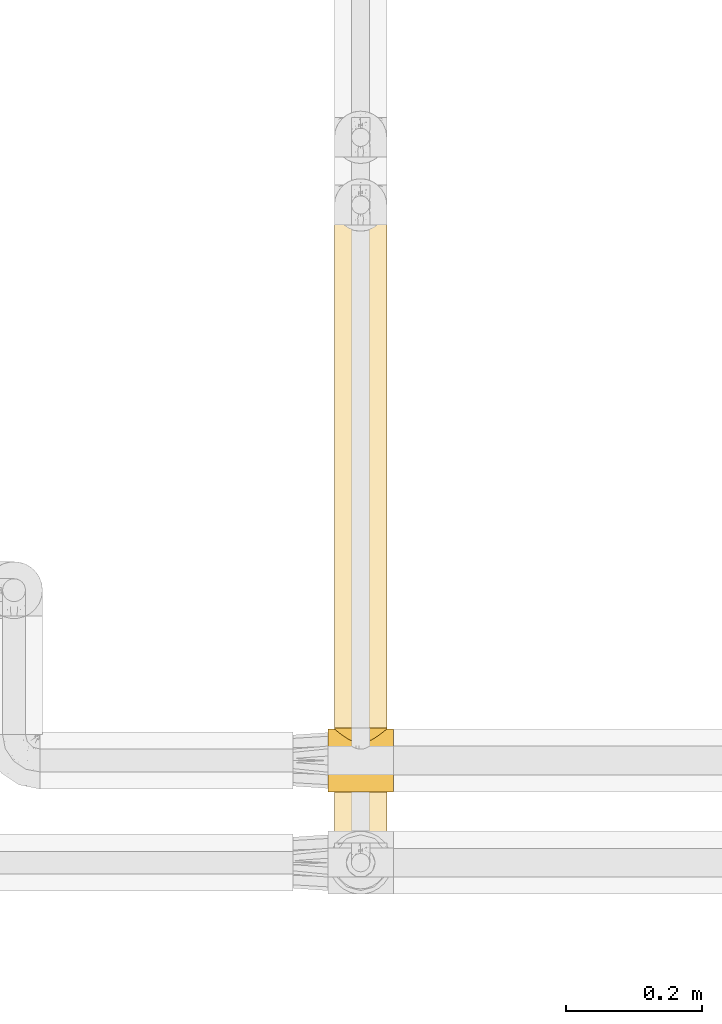
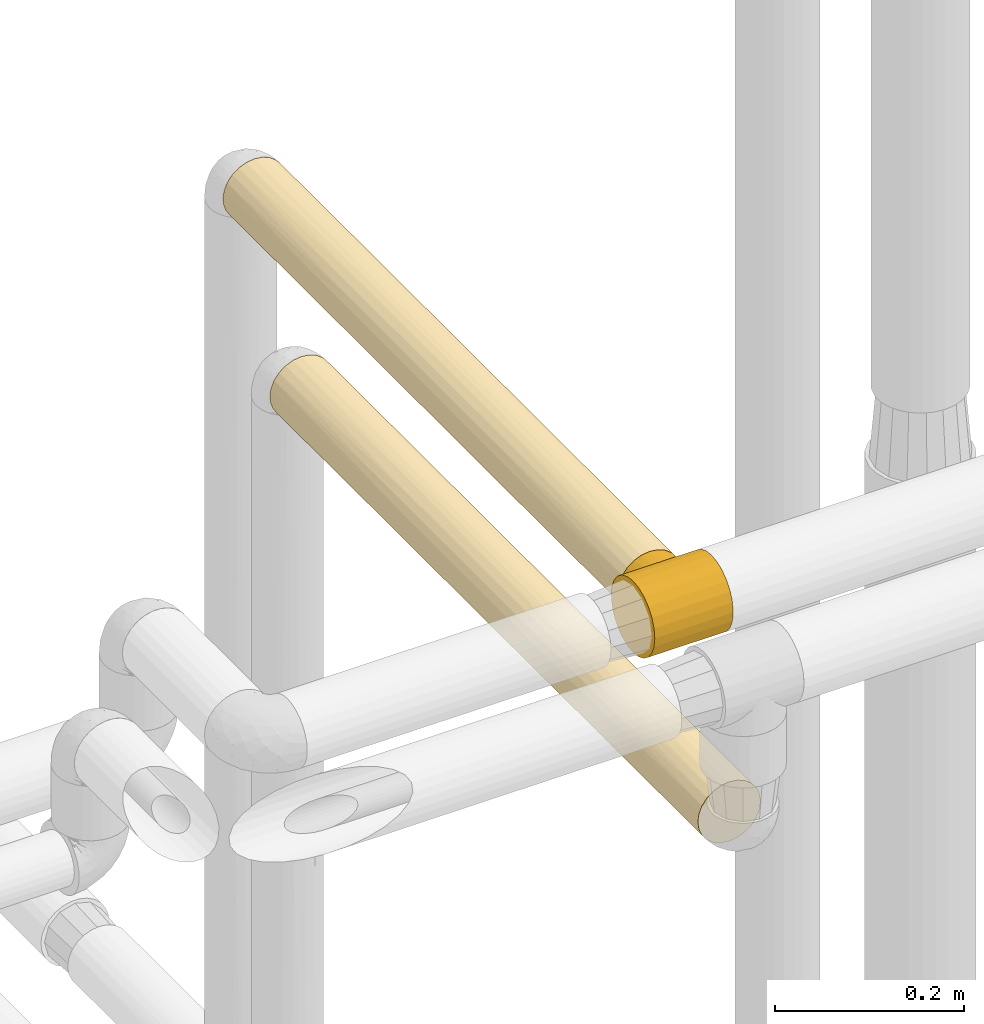
# One storey, part 98 of 827: 3 coverings.
"""IFC2X3 building model written with IfcOpenShell, lengths in millimetres."""

from ifc_helpers import new_model, entity, si_unit, converted_unit, derived_unit, direction, frame, origin, place, context, subcontext, project, spatial, faceted_brep, element, save


model = new_model("IFC2X3")

# Units and contexts
model_context = context("Model", 3, precision=0.01, world=origin(), true_north=direction((6.12303176911189e-17, 1.0)))
body_context = subcontext(model_context, "Body", "Model", "MODEL_VIEW")
ifc_project = project(units=[si_unit("LENGTHUNIT", "METRE", prefix="MILLI"), si_unit("AREAUNIT", "SQUARE_METRE"), si_unit("VOLUMEUNIT", "CUBIC_METRE"), converted_unit("PLANEANGLEUNIT", "DEGREE", entity("IfcRatioMeasure", 0.0174532925199433), si_unit("PLANEANGLEUNIT", "RADIAN"), dimensions=[0, 0, 0, 0, 0, 0, 0]), si_unit("MASSUNIT", "GRAM", prefix="KILO"), derived_unit("MASSDENSITYUNIT", [(si_unit("MASSUNIT", "GRAM", prefix="KILO"), 1), (si_unit("LENGTHUNIT", "METRE"), -3)]), derived_unit("MOMENTOFINERTIAUNIT", [(si_unit("LENGTHUNIT", "METRE"), 4)]), si_unit("TIMEUNIT", "SECOND"), si_unit("FREQUENCYUNIT", "HERTZ"), si_unit("THERMODYNAMICTEMPERATUREUNIT", "DEGREE_CELSIUS"), derived_unit("THERMALTRANSMITTANCEUNIT", [(si_unit("MASSUNIT", "GRAM", prefix="KILO"), 1), (si_unit("THERMODYNAMICTEMPERATUREUNIT", "KELVIN"), -1), (si_unit("TIMEUNIT", "SECOND"), -3)]), derived_unit("VOLUMETRICFLOWRATEUNIT", [(si_unit("LENGTHUNIT", "METRE"), 3), (si_unit("TIMEUNIT", "SECOND"), -1)]), derived_unit("MASSFLOWRATEUNIT", [(si_unit("MASSUNIT", "GRAM", prefix="KILO"), 1), (si_unit("TIMEUNIT", "SECOND"), -1)]), derived_unit("ROTATIONALFREQUENCYUNIT", [(si_unit("TIMEUNIT", "SECOND"), -1)]), si_unit("ELECTRICCURRENTUNIT", "AMPERE"), si_unit("ELECTRICVOLTAGEUNIT", "VOLT"), si_unit("POWERUNIT", "WATT"), si_unit("FORCEUNIT", "NEWTON", prefix="KILO"), si_unit("ILLUMINANCEUNIT", "LUX"), si_unit("LUMINOUSFLUXUNIT", "LUMEN"), si_unit("LUMINOUSINTENSITYUNIT", "CANDELA"), derived_unit("USERDEFINED", [(si_unit("MASSUNIT", "GRAM", prefix="KILO"), -1), (si_unit("LENGTHUNIT", "METRE"), -2), (si_unit("TIMEUNIT", "SECOND"), 3), (si_unit("LUMINOUSFLUXUNIT", "LUMEN"), 1)]), derived_unit("LINEARVELOCITYUNIT", [(si_unit("LENGTHUNIT", "METRE"), 1), (si_unit("TIMEUNIT", "SECOND"), -1)]), si_unit("PRESSUREUNIT", "PASCAL"), derived_unit("USERDEFINED", [(si_unit("LENGTHUNIT", "METRE"), -2), (si_unit("MASSUNIT", "GRAM", prefix="KILO"), 1), (si_unit("TIMEUNIT", "SECOND"), -2)]), derived_unit("LINEARFORCEUNIT", [(si_unit("MASSUNIT", "GRAM", prefix="KILO"), 1), (si_unit("LENGTHUNIT", "METRE"), 1), (si_unit("TIMEUNIT", "SECOND"), -2), (si_unit("LENGTHUNIT", "METRE"), -1)]), derived_unit("PLANARFORCEUNIT", [(si_unit("MASSUNIT", "GRAM", prefix="KILO"), 1), (si_unit("LENGTHUNIT", "METRE"), 1), (si_unit("TIMEUNIT", "SECOND"), -2), (si_unit("LENGTHUNIT", "METRE"), -2)])], contexts=[model_context])

# Site, building, storey
site_placement = place(None, origin())
site = spatial("IfcSite", under=ifc_project, at=site_placement, CompositionType="ELEMENT")
building_placement = place(site_placement, origin())
building = spatial("IfcBuilding", under=site, at=building_placement, CompositionType="ELEMENT")
storey_placement = place(building_placement, frame((0.0, 0.0, 28200.0)))
storey = spatial("IfcBuildingStorey", under=building, at=storey_placement, Name="08", CompositionType="ELEMENT", Elevation=28200.0)

# Coverings
covering_1_placement = place(storey_placement, frame((19736.27, 9540.79, 2957.23)))
element("IfcCovering", 1, at=covering_1_placement, inside=storey, Name=":ADSK_", ObjectType=":ADSK_", PredefinedType="INSULATION", context=body_context, shape_type="Brep", body=[
    faceted_brep([(30.06, 0.01, 2.9), (40.0, 0.01, 1.6), (49.93, 0.01, 2.9), (59.2, 0.01, 6.74), (67.15, 0.01, 12.84), (73.25, 0.01, 20.8), (77.09, 0.01, 30.06), (78.4, 0.0, 40.0), (77.09, 0.0, 49.93), (73.25, 0.0, 59.2), (67.15, 0.0, 67.15), (59.2, 0.0, 73.25), (49.93, 0.0, 77.09), (40.0, 0.0, 78.4), (30.06, 0.0, 77.09), (20.8, 0.0, 73.25), (12.84, 0.0, 67.15), (6.74, 0.0, 59.2), (2.9, 0.0, 49.93), (1.6, 0.0, 40.0), (2.9, 0.01, 30.06), (6.74, 0.01, 20.8), (12.84, 0.01, 12.84), (20.8, 0.01, 6.74), (65.05, 837.69, 10.99), (14.94, 837.69, 10.99), (9.31, 837.69, 17.0), (5.09, 837.69, 24.08), (2.48, 837.69, 31.89), (1.6, 837.69, 40.09), (2.9, 837.69, 50.03), (6.74, 837.68, 59.29), (12.84, 837.68, 67.24), (20.8, 837.68, 73.35), (30.06, 837.68, 77.18), (40.0, 837.68, 78.49), (49.93, 837.68, 77.18), (59.2, 837.68, 73.35), (67.15, 837.68, 67.24), (73.25, 837.68, 59.29), (77.09, 837.69, 50.03), (78.4, 837.69, 40.09), (77.51, 837.69, 31.89), (74.9, 837.69, 24.08), (70.68, 837.69, 17.0), (7.01, 649.63, 20.41), (3.58, 580.77, 27.88), (9.53, 208.61, 16.64), (33.21, 829.0, 2.3), (40.0, 612.02, 1.67), (29.79, 521.8, 3.04), (40.0, 216.38, 1.62), (1.6, 621.31, 40.07), (1.6, 628.27, 40.07), (11.96, 591.71, 13.82), (3.36, 288.81, 28.51), (1.6, 404.94, 40.04), (1.6, 202.47, 40.02), (14.88, 210.24, 10.97), (7.01, 427.14, 20.38), (20.48, 833.72, 7.02), (17.6, 636.26, 8.88), (22.89, 519.54, 5.67), (17.38, 415.45, 9.01), (26.63, 830.79, 4.09), (5.75, 196.04, 22.64), (1.6, 418.85, 40.04), (25.3, 258.72, 4.55), (40.0, 395.64, 1.64), (32.73, 306.01, 2.32), (40.0, 828.39, 1.69), (1.6, 216.38, 40.02), (46.78, 829.0, 2.3), (53.36, 830.79, 4.09), (50.2, 521.8, 3.04), (54.69, 258.72, 4.55), (65.11, 210.24, 10.97), (57.1, 519.54, 5.67), (59.51, 833.72, 7.02), (68.03, 591.71, 13.82), (62.39, 636.26, 8.88), (76.63, 288.81, 28.51), (76.41, 580.77, 27.88), (78.4, 404.94, 40.04), (47.26, 306.01, 2.32), (72.98, 427.14, 20.38), (72.98, 649.63, 20.41), (78.4, 621.32, 40.07), (70.46, 208.61, 16.64), (78.4, 202.47, 40.02), (78.4, 216.38, 40.02), (74.24, 196.04, 22.64), (62.61, 415.45, 9.01), (78.4, 635.22, 40.07), (78.4, 432.75, 40.05), (70.46, 418.84, 63.42), (70.46, 184.37, 63.39), (75.47, 284.57, 54.72), (75.47, 580.09, 54.76), (70.46, 653.31, 63.45), (63.37, 580.09, 70.53), (55.09, 649.02, 75.38), (77.73, 324.56, 47.13), (77.78, 561.02, 46.92), (54.69, 418.84, 75.52), (63.37, 284.56, 70.49), (47.8, 581.39, 77.66), (53.81, 193.85, 75.85), (40.0, 635.21, 78.47), (40.0, 628.26, 78.47), (40.0, 432.75, 78.45), (40.0, 418.84, 78.44), (40.0, 216.37, 78.42), (47.49, 317.61, 77.69), (16.62, 418.84, 70.51), (16.62, 184.37, 70.48), (25.3, 284.56, 75.51), (25.3, 580.09, 75.54), (16.62, 653.31, 70.54), (9.53, 580.09, 63.44), (4.69, 649.02, 55.16), (32.9, 324.56, 77.77), (33.13, 561.02, 77.84), (4.52, 418.84, 54.74), (9.53, 284.57, 63.4), (2.4, 581.39, 47.87), (4.17, 193.85, 53.83), (2.33, 317.61, 47.52)], [[[0, 1, 2, 3, 4, 5, 6, 7, 8, 9, 10, 11, 12, 13, 14, 15, 16, 17, 18, 19, 20, 21, 22, 23]], [[24, 25, 26, 27, 28, 29, 30, 31, 32, 33, 34, 35, 36, 37, 38, 39, 40, 41, 42, 43, 44]], [[45, 46, 27]], [[22, 21, 47]], [[27, 26, 45]], [[48, 49, 50]], [[1, 0, 51]], [[28, 52, 53, 29]], [[46, 52, 28]], [[54, 26, 25]], [[55, 56, 46]], [[20, 57, 55]], [[22, 47, 58]], [[55, 46, 59]], [[25, 60, 61]], [[62, 63, 61]], [[64, 50, 62]], [[50, 64, 48]], [[28, 27, 46]], [[22, 58, 23]], [[65, 20, 55]], [[46, 56, 66, 52]], [[45, 54, 59]], [[63, 62, 67]], [[68, 51, 69]], [[67, 0, 23]], [[59, 47, 65]], [[67, 23, 58]], [[63, 54, 61]], [[50, 68, 69]], [[54, 63, 58]], [[54, 45, 26]], [[46, 45, 59]], [[65, 47, 21]], [[47, 59, 54]], [[54, 58, 47]], [[58, 63, 67]], [[69, 0, 67]], [[0, 69, 51]], [[50, 69, 67]], [[25, 61, 54]], [[60, 64, 62]], [[62, 61, 60]], [[67, 62, 50]], [[20, 65, 21]], [[59, 65, 55]], [[49, 48, 70]], [[49, 68, 50]], [[57, 20, 19]], [[55, 57, 71, 56]], [[70, 72, 49]], [[72, 73, 74]], [[2, 75, 3]], [[75, 76, 3]], [[77, 73, 78]], [[79, 80, 24]], [[72, 74, 49]], [[75, 74, 77]], [[81, 82, 83]], [[79, 24, 44]], [[68, 84, 51]], [[85, 82, 81]], [[74, 84, 68]], [[51, 84, 2]], [[86, 44, 43]], [[42, 87, 82]], [[86, 82, 85]], [[86, 79, 44]], [[88, 79, 85]], [[81, 89, 6]], [[77, 78, 80]], [[79, 88, 76]], [[81, 83, 90, 89]], [[42, 82, 43]], [[88, 91, 5]], [[76, 75, 92]], [[6, 89, 7]], [[92, 80, 79]], [[91, 6, 5]], [[88, 5, 4]], [[82, 86, 43]], [[79, 86, 85]], [[76, 88, 4]], [[91, 85, 81]], [[3, 76, 4]], [[79, 76, 92]], [[2, 1, 51]], [[74, 75, 84]], [[2, 84, 75]], [[77, 80, 92]], [[24, 80, 78]], [[75, 77, 92]], [[73, 77, 74]], [[85, 91, 88]], [[6, 91, 81]], [[74, 68, 49]], [[42, 41, 93, 87]], [[82, 87, 94, 83]], [[95, 96, 97, 98, 99]], [[100, 37, 101]], [[102, 94, 103]], [[39, 98, 40]], [[40, 103, 93]], [[38, 99, 39]], [[102, 90, 83, 94]], [[96, 10, 9]], [[9, 8, 97]], [[104, 105, 100]], [[95, 99, 100, 105, 96]], [[36, 106, 101]], [[107, 105, 104]], [[106, 35, 108, 109, 110, 111]], [[96, 105, 10]], [[37, 100, 38]], [[8, 90, 102]], [[11, 10, 105]], [[13, 12, 112]], [[104, 113, 107]], [[102, 103, 98]], [[113, 104, 106]], [[98, 39, 99]], [[12, 107, 113]], [[8, 7, 89, 90]], [[93, 41, 40]], [[98, 97, 102]], [[8, 102, 97]], [[40, 98, 103]], [[12, 113, 112]], [[111, 112, 113]], [[104, 101, 106]], [[111, 113, 106]], [[12, 11, 107]], [[105, 107, 11]], [[100, 101, 104]], [[36, 101, 37]], [[103, 94, 87, 93]], [[97, 96, 9]], [[100, 99, 38]], [[35, 106, 36]], [[114, 115, 116, 117, 118]], [[119, 31, 120]], [[121, 110, 122]], [[33, 117, 34]], [[34, 122, 108]], [[32, 118, 33]], [[121, 112, 111, 110]], [[115, 16, 15]], [[15, 14, 116]], [[123, 124, 119]], [[114, 118, 119, 124, 115]], [[30, 125, 120]], [[126, 124, 123]], [[125, 29, 53, 52, 66]], [[115, 124, 16]], [[31, 119, 32]], [[14, 112, 121]], [[17, 16, 124]], [[18, 71, 57, 19]], [[123, 127, 126]], [[121, 122, 117]], [[127, 123, 125]], [[117, 33, 118]], [[18, 126, 127]], [[14, 13, 112]], [[108, 35, 34]], [[117, 116, 121]], [[14, 121, 116]], [[34, 117, 122]], [[18, 127, 71]], [[127, 66, 56, 71]], [[123, 120, 125]], [[66, 127, 125]], [[18, 17, 126]], [[124, 126, 17]], [[119, 120, 123]], [[30, 120, 31]], [[122, 110, 109, 108]], [[116, 115, 15]], [[119, 118, 32]], [[29, 125, 30]], [[78, 73, 72, 70, 48, 64, 60, 25, 24]]]),
])
covering_2_placement = place(storey_placement, frame((19736.27, 9371.9, 2761.73)))
element("IfcCovering", 2, at=covering_2_placement, inside=storey, Name=":ADSK_", ObjectType=":ADSK_", PredefinedType="INSULATION", context=body_context, shape_type="Brep", body=[
    faceted_brep([(20.8, 907.25, 73.25), (30.06, 907.25, 77.09), (40.0, 907.25, 78.4), (49.93, 907.25, 77.09), (59.2, 907.25, 73.25), (67.15, 907.25, 67.15), (73.25, 907.25, 59.2), (77.09, 907.25, 49.93), (78.4, 907.25, 40.0), (77.51, 907.25, 31.79), (74.9, 907.25, 23.98), (70.68, 907.25, 16.91), (65.05, 907.25, 10.9), (14.94, 907.25, 10.9), (9.31, 907.25, 16.91), (5.09, 907.25, 23.98), (2.48, 907.25, 31.79), (1.6, 907.25, 40.0), (2.9, 907.25, 49.93), (6.74, 907.25, 59.2), (12.84, 907.25, 67.15), (20.8, 0.0, 73.25), (12.84, 0.0, 67.15), (6.74, 0.0, 59.2), (2.9, 0.0, 49.93), (1.6, 0.0, 40.0), (2.9, 0.0, 30.06), (6.74, 0.0, 20.8), (12.84, 0.0, 12.84), (20.8, 0.0, 6.74), (30.06, 0.0, 2.9), (40.0, 0.0, 1.6), (49.93, 0.0, 2.9), (59.2, 0.0, 6.74), (67.15, 0.0, 12.84), (73.25, 0.0, 20.8), (77.09, 0.0, 30.06), (78.4, 0.0, 40.0), (77.09, 0.0, 49.93), (73.25, 0.0, 59.2), (67.15, 0.0, 67.15), (59.2, 0.0, 73.25), (49.93, 0.0, 77.09), (40.0, 0.0, 78.4), (30.06, 0.0, 77.09), (76.89, 322.72, 29.36), (78.4, 237.25, 40.0), (47.03, 340.79, 2.25), (40.0, 216.37, 1.6), (40.0, 465.2, 1.6), (68.22, 573.79, 13.96), (68.61, 293.3, 14.39), (62.63, 450.32, 8.97), (78.4, 690.88, 40.0), (76.41, 642.74, 27.82), (57.18, 565.7, 5.66), (59.51, 903.28, 6.92), (62.49, 688.42, 8.88), (72.98, 476.72, 20.33), (73.32, 238.75, 20.92), (72.98, 708.41, 20.33), (78.4, 474.5, 40.0), (78.4, 432.75, 40.0), (62.8, 208.07, 9.1), (54.69, 278.61, 4.52), (40.0, 681.58, 1.6), (46.78, 898.56, 2.2), (50.2, 591.36, 2.98), (78.4, 216.37, 40.0), (53.36, 900.35, 4.0), (40.0, 897.95, 1.6), (25.3, 278.61, 4.52), (17.19, 208.07, 9.1), (11.38, 293.3, 14.39), (11.77, 573.79, 13.96), (17.36, 450.32, 8.97), (32.96, 340.79, 2.25), (22.81, 565.7, 5.66), (29.79, 591.36, 2.98), (26.63, 900.35, 4.0), (33.21, 898.56, 2.2), (4.52, 243.32, 25.3), (17.5, 688.42, 8.88), (20.48, 903.28, 6.92), (2.97, 582.69, 29.81), (2.29, 345.44, 32.75), (1.6, 216.37, 40.0), (1.6, 474.51, 40.0), (1.6, 690.88, 40.0), (7.01, 476.72, 20.33), (7.01, 708.41, 20.33), (9.53, 453.63, 63.37), (4.52, 611.06, 54.69), (4.52, 288.36, 54.69), (16.62, 624.19, 70.46), (9.53, 703.56, 63.37), (2.26, 575.74, 47.13), (2.23, 345.44, 46.96), (9.53, 203.69, 63.37), (16.62, 296.19, 70.46), (25.3, 493.12, 75.47), (31.54, 280.76, 77.45), (32.97, 561.81, 77.75), (23.67, 257.23, 74.75), (27.35, 703.42, 76.25), (40.0, 216.38, 78.4), (40.0, 690.88, 78.4), (40.0, 432.75, 78.4), (40.0, 474.5, 78.4), (63.37, 453.63, 70.46), (63.37, 703.56, 70.46), (54.69, 611.06, 75.47), (54.69, 288.36, 75.47), (63.37, 203.69, 70.46), (70.46, 624.19, 63.37), (47.13, 575.74, 77.73), (46.96, 345.44, 77.76), (70.46, 296.19, 63.37), (75.47, 493.12, 54.69), (77.45, 280.76, 48.45), (77.75, 561.81, 47.02), (74.75, 257.23, 56.32), (76.25, 703.42, 52.64)], [[[0, 1, 2, 3, 4, 5, 6, 7, 8, 9, 10, 11, 12, 13, 14, 15, 16, 17, 18, 19, 20]], [[21, 22, 23, 24, 25, 26, 27, 28, 29, 30, 31, 32, 33, 34, 35, 36, 37, 38, 39, 40, 41, 42, 43, 44]], [[45, 46, 36]], [[47, 48, 49]], [[50, 51, 52]], [[9, 53, 54]], [[55, 56, 57]], [[10, 9, 54]], [[58, 54, 45]], [[35, 34, 59]], [[36, 35, 59]], [[54, 58, 60]], [[50, 52, 57]], [[45, 61, 62, 46]], [[60, 11, 10]], [[52, 63, 64]], [[60, 50, 11]], [[48, 47, 32]], [[54, 61, 45]], [[65, 66, 67]], [[36, 46, 68, 37]], [[66, 69, 67]], [[63, 52, 51]], [[12, 57, 56]], [[65, 70, 66]], [[55, 69, 56]], [[67, 47, 49]], [[59, 34, 51]], [[55, 57, 52]], [[64, 33, 32]], [[55, 64, 67]], [[50, 12, 11]], [[50, 57, 12]], [[51, 50, 58]], [[51, 58, 59]], [[63, 34, 33]], [[54, 60, 10]], [[50, 60, 58]], [[32, 31, 48]], [[67, 64, 47]], [[32, 47, 64]], [[64, 55, 52]], [[69, 55, 67]], [[34, 63, 51]], [[64, 63, 33]], [[58, 45, 59]], [[36, 59, 45]], [[67, 49, 65]], [[53, 9, 8]], [[53, 61, 54]], [[71, 29, 72]], [[73, 74, 75]], [[76, 49, 48]], [[77, 71, 75]], [[78, 49, 76]], [[78, 79, 80]], [[29, 71, 30]], [[81, 73, 27]], [[79, 78, 77]], [[73, 72, 28]], [[80, 65, 78]], [[82, 13, 83]], [[13, 74, 14]], [[84, 81, 85]], [[83, 79, 77]], [[26, 25, 86]], [[87, 88, 84]], [[89, 73, 81]], [[89, 74, 73]], [[27, 26, 81]], [[90, 15, 14]], [[77, 75, 82]], [[16, 88, 17]], [[16, 15, 84]], [[31, 30, 48]], [[15, 90, 84]], [[82, 74, 13]], [[82, 75, 74]], [[16, 84, 88]], [[74, 89, 90]], [[72, 73, 75]], [[27, 73, 28]], [[86, 85, 26]], [[84, 89, 81]], [[85, 86, 87]], [[74, 90, 14]], [[84, 90, 89]], [[84, 85, 87]], [[26, 85, 81]], [[76, 30, 71]], [[30, 76, 48]], [[78, 76, 71]], [[77, 82, 83]], [[71, 77, 78]], [[71, 72, 75]], [[28, 72, 29]], [[65, 80, 70]], [[65, 49, 78]], [[91, 92, 93]], [[94, 20, 95]], [[96, 97, 92]], [[95, 92, 91]], [[23, 93, 24]], [[97, 87, 86]], [[22, 98, 23]], [[18, 88, 96]], [[95, 20, 19]], [[19, 18, 92]], [[21, 99, 22]], [[99, 100, 94]], [[100, 101, 102]], [[100, 103, 101]], [[25, 24, 86]], [[88, 18, 17]], [[104, 100, 102]], [[99, 94, 95, 91, 98]], [[0, 20, 94]], [[103, 44, 101]], [[44, 105, 101]], [[106, 2, 1]], [[105, 44, 43]], [[87, 97, 96]], [[100, 104, 94]], [[93, 23, 98]], [[1, 104, 102]], [[97, 24, 93]], [[1, 102, 106]], [[102, 107, 108, 106]], [[103, 100, 99]], [[107, 102, 101]], [[24, 97, 86]], [[92, 97, 93]], [[92, 18, 96]], [[1, 0, 104]], [[88, 87, 96]], [[94, 104, 0]], [[92, 95, 19]], [[99, 98, 22]], [[93, 98, 91]], [[99, 21, 103]], [[44, 103, 21]], [[105, 107, 101]], [[109, 110, 111, 112, 113]], [[114, 5, 110]], [[115, 116, 111]], [[41, 112, 42]], [[116, 108, 107, 105]], [[40, 113, 41]], [[3, 106, 115]], [[110, 5, 4]], [[4, 3, 111]], [[39, 117, 40]], [[117, 118, 114]], [[118, 119, 120]], [[118, 121, 119]], [[43, 42, 105]], [[106, 3, 2]], [[122, 118, 120]], [[117, 114, 110, 109, 113]], [[6, 5, 114]], [[121, 38, 119]], [[38, 68, 119]], [[53, 8, 7]], [[68, 38, 37]], [[108, 116, 115]], [[118, 122, 114]], [[112, 41, 113]], [[7, 122, 120]], [[116, 42, 112]], [[7, 120, 53]], [[120, 62, 61, 53]], [[121, 118, 117]], [[62, 120, 119]], [[42, 116, 105]], [[111, 116, 112]], [[111, 3, 115]], [[7, 6, 122]], [[106, 108, 115]], [[114, 122, 6]], [[111, 110, 4]], [[117, 113, 40]], [[117, 39, 121]], [[38, 121, 39]], [[119, 68, 46, 62]], [[69, 66, 70, 80, 79, 83, 13, 12, 56]]]),
])
covering_3_placement = place(storey_placement, frame((19728.27, 9445.0, 2949.43)))
element("IfcCovering", 3, at=covering_3_placement, inside=storey, Name=":ADSK_", ObjectType=":ADSK_", PredefinedType="INSULATION", context=body_context, shape_type="Brep", body=[
    faceted_brep([(0.0, 7.78, 24.7), (0.0, 3.17, 35.84), (0.0, 1.6, 47.8), (0.0, 3.17, 59.75), (0.0, 7.78, 70.9), (0.0, 15.13, 80.47), (0.0, 24.7, 87.81), (0.0, 35.84, 92.42), (0.0, 47.8, 94.0), (0.0, 59.75, 92.42), (0.0, 70.9, 87.81), (0.0, 80.46, 80.47), (0.0, 84.13, 75.68), (0.0, 87.81, 70.9), (0.0, 88.96, 68.11), (0.0, 90.11, 65.33), (0.0, 91.27, 62.54), (0.0, 92.42, 59.75), (0.0, 92.81, 56.77), (0.0, 93.21, 53.78), (0.0, 93.6, 50.79), (0.0, 94.0, 47.8), (0.0, 93.6, 44.81), (0.0, 93.21, 41.82), (0.0, 92.81, 38.83), (0.0, 92.42, 35.84), (0.0, 91.27, 33.05), (0.0, 90.11, 30.27), (0.0, 88.96, 27.48), (0.0, 87.81, 24.7), (0.0, 84.13, 19.91), (0.0, 80.46, 15.13), (0.0, 70.9, 7.79), (0.0, 59.75, 3.17), (0.0, 47.8, 1.6), (0.0, 35.84, 3.17), (0.0, 24.7, 7.79), (0.0, 15.13, 15.13), (96.0, 47.8, 94.0), (96.0, 35.84, 92.42), (96.0, 24.7, 87.81), (96.0, 15.13, 80.46), (96.0, 7.78, 70.9), (96.0, 3.17, 59.75), (96.0, 1.6, 47.8), (96.0, 3.17, 35.84), (96.0, 7.78, 24.7), (96.0, 15.13, 15.13), (96.0, 24.7, 7.78), (96.0, 35.84, 3.17), (96.0, 47.8, 1.6), (96.0, 59.75, 3.17), (96.0, 70.9, 7.78), (96.0, 80.46, 15.13), (96.0, 84.13, 19.91), (96.0, 87.81, 24.7), (96.0, 88.96, 27.48), (96.0, 90.11, 30.27), (96.0, 91.27, 33.05), (96.0, 92.42, 35.84), (96.0, 92.81, 38.83), (96.0, 93.21, 41.82), (96.0, 93.6, 44.81), (96.0, 94.0, 47.8), (96.0, 93.6, 50.78), (96.0, 93.21, 53.77), (96.0, 92.81, 56.76), (96.0, 92.42, 59.75), (96.0, 91.27, 62.54), (96.0, 90.11, 65.32), (96.0, 88.96, 68.11), (96.0, 87.81, 70.9), (96.0, 84.13, 75.68), (96.0, 80.46, 80.46), (96.0, 70.9, 87.81), (96.0, 59.75, 92.42), (48.0, 73.41, 86.25), (71.83, 82.78, 77.97), (64.94, 78.51, 82.31), (77.67, 86.99, 72.25), (13.7, 90.6, 65.18), (12.17, 91.85, 61.03), (56.98, 74.93, 85.18), (79.98, 88.8, 68.72), (85.91, 93.54, 52.34), (85.63, 93.32, 54.61), (31.06, 78.51, 82.31), (39.03, 74.93, 85.18), (9.82, 93.77, 50.07), (24.17, 82.78, 77.97), (18.33, 86.99, 72.25), (16.02, 88.8, 68.72), (82.3, 90.6, 65.18), (83.83, 91.85, 61.03), (86.18, 93.77, 50.07), (9.55, 94.0, 47.8), (86.45, 94.0, 47.8), (85.36, 93.09, 56.88), (11.41, 92.47, 58.95), (84.6, 92.47, 58.95), (10.1, 93.54, 52.34), (10.37, 93.32, 54.61), (10.64, 93.09, 56.88), (85.91, 93.54, 43.25), (84.6, 92.47, 36.64), (83.83, 91.85, 34.56), (79.98, 88.8, 26.88), (11.41, 92.47, 36.64), (10.64, 93.09, 38.71), (82.3, 90.6, 30.41), (77.67, 86.99, 23.34), (85.36, 93.09, 38.71), (10.37, 93.32, 40.98), (9.82, 93.77, 45.53), (10.09, 93.54, 43.26), (85.63, 93.32, 40.98), (16.02, 88.8, 26.88), (18.33, 86.99, 23.34), (71.83, 82.78, 17.62), (12.17, 91.85, 34.56), (24.17, 82.78, 17.62), (13.7, 90.6, 30.41), (86.18, 93.77, 45.52), (64.94, 78.51, 13.28), (48.0, 73.41, 9.35), (56.97, 74.93, 10.41), (31.06, 78.51, 13.28), (39.03, 74.93, 10.41), (48.0, 95.8, 86.25), (57.95, 95.8, 84.94), (67.23, 95.8, 81.09), (75.19, 95.8, 74.98), (81.3, 95.8, 67.02), (83.22, 95.8, 62.38), (85.14, 95.8, 57.75), (85.47, 95.8, 55.26), (85.8, 95.8, 52.77), (86.12, 95.8, 50.28), (86.45, 95.8, 47.8), (86.12, 95.8, 45.31), (85.8, 95.8, 42.82), (85.47, 95.8, 40.33), (85.14, 95.8, 37.84), (83.22, 95.8, 33.21), (81.3, 95.8, 28.57), (75.19, 95.8, 20.61), (67.23, 95.8, 14.5), (57.95, 95.8, 10.66), (48.0, 95.8, 9.35), (38.05, 95.8, 10.66), (28.78, 95.8, 14.5), (20.81, 95.8, 20.61), (14.7, 95.8, 28.57), (12.78, 95.8, 33.21), (10.86, 95.8, 37.85), (10.53, 95.8, 40.33), (10.21, 95.8, 42.82), (9.88, 95.8, 45.31), (9.55, 95.8, 47.8), (9.88, 95.8, 50.28), (10.21, 95.8, 52.77), (10.53, 95.8, 55.26), (10.86, 95.8, 57.75), (12.78, 95.8, 62.39), (14.7, 95.8, 67.02), (20.81, 95.8, 74.98), (28.78, 95.8, 81.1), (38.05, 95.8, 84.94)], [[[0, 1, 2, 3, 4, 5, 6, 7, 8, 9, 10, 11, 12, 13, 14, 15, 16, 17, 18, 19, 20, 21, 22, 23, 24, 25, 26, 27, 28, 29, 30, 31, 32, 33, 34, 35, 36, 37]], [[38, 39, 40, 41, 42, 43, 44, 45, 46, 47, 48, 49, 50, 51, 52, 53, 54, 55, 56, 57, 58, 59, 60, 61, 62, 63, 64, 65, 66, 67, 68, 69, 70, 71, 72, 73, 74, 75]], [[3, 43, 42, 4]], [[4, 42, 41, 5]], [[44, 43, 3, 2]], [[6, 40, 39, 7]], [[7, 39, 38, 8]], [[5, 41, 40, 6]], [[75, 9, 8, 38]], [[74, 76, 75]], [[73, 77, 78]], [[72, 71, 79]], [[16, 80, 81]], [[82, 74, 78]], [[77, 73, 72]], [[78, 74, 73]], [[82, 76, 74]], [[9, 76, 10]], [[83, 71, 70]], [[65, 84, 85]], [[86, 10, 87]], [[88, 21, 20]], [[11, 10, 86]], [[89, 11, 86]], [[90, 12, 89]], [[87, 10, 76]], [[75, 76, 9]], [[80, 14, 91]], [[70, 92, 83]], [[92, 68, 93]], [[79, 71, 83]], [[66, 65, 85]], [[68, 67, 93]], [[92, 70, 69, 68]], [[84, 64, 94]], [[21, 88, 95]], [[94, 63, 96]], [[80, 16, 15, 14]], [[66, 85, 97]], [[17, 81, 98]], [[63, 94, 64]], [[99, 66, 97]], [[90, 13, 12]], [[67, 99, 93]], [[91, 14, 13]], [[13, 90, 91]], [[89, 12, 11]], [[20, 19, 100]], [[101, 18, 102]], [[18, 101, 19]], [[17, 98, 18]], [[18, 98, 102]], [[66, 99, 67]], [[19, 101, 100]], [[84, 65, 64]], [[77, 72, 79]], [[20, 100, 88]], [[81, 17, 16]], [[61, 103, 62]], [[60, 59, 104]], [[105, 59, 58]], [[55, 106, 56]], [[107, 24, 108]], [[57, 56, 109, 58]], [[54, 110, 55]], [[104, 111, 60]], [[58, 109, 105]], [[24, 112, 108]], [[24, 107, 25]], [[22, 113, 114]], [[115, 60, 111]], [[116, 117, 29]], [[110, 54, 118]], [[116, 29, 28]], [[25, 119, 26]], [[120, 30, 117]], [[26, 121, 28, 27]], [[122, 63, 62]], [[109, 56, 106]], [[59, 105, 104]], [[118, 53, 123]], [[53, 118, 54]], [[123, 53, 52]], [[124, 52, 51]], [[63, 122, 96]], [[113, 21, 95]], [[124, 125, 52]], [[52, 125, 123]], [[51, 50, 34, 33]], [[114, 23, 22]], [[21, 113, 22]], [[24, 23, 112]], [[31, 126, 32]], [[28, 121, 116]], [[30, 29, 117]], [[31, 120, 126]], [[126, 127, 32]], [[25, 107, 119]], [[124, 32, 127]], [[32, 124, 33]], [[60, 115, 61]], [[33, 124, 51]], [[121, 26, 119]], [[120, 31, 30]], [[23, 114, 112]], [[55, 110, 106]], [[62, 103, 122]], [[61, 115, 103]], [[35, 49, 48, 36]], [[36, 48, 47, 37]], [[50, 49, 35, 34]], [[0, 46, 45, 1]], [[1, 45, 44, 2]], [[37, 47, 46, 0]], [[128, 129, 130, 131, 132, 133, 134, 135, 136, 137, 138, 139, 140, 141, 142, 143, 144, 145, 146, 147, 148, 149, 150, 151, 152, 153, 154, 155, 156, 157, 158, 159, 160, 161, 162, 163, 164, 165, 166, 167]], [[97, 135, 134]], [[92, 133, 132]], [[94, 138, 137]], [[137, 136, 84]], [[134, 93, 99, 97]], [[132, 79, 83, 92]], [[133, 93, 134]], [[133, 92, 93]], [[132, 131, 79]], [[137, 84, 94]], [[77, 131, 130]], [[138, 94, 96]], [[129, 128, 82]], [[85, 136, 135]], [[78, 130, 129]], [[136, 85, 84]], [[77, 130, 78]], [[82, 78, 129]], [[76, 82, 128]], [[135, 97, 85]], [[131, 77, 79]], [[87, 128, 167]], [[86, 167, 166]], [[160, 101, 161]], [[76, 128, 87]], [[102, 162, 161]], [[87, 167, 86]], [[166, 89, 86]], [[88, 158, 95]], [[166, 165, 89]], [[90, 165, 164]], [[162, 102, 98, 81]], [[159, 88, 100]], [[160, 100, 101]], [[164, 80, 91, 90]], [[80, 164, 163]], [[161, 101, 102]], [[163, 81, 80]], [[162, 81, 163]], [[158, 88, 159]], [[165, 90, 89]], [[100, 160, 159]], [[108, 155, 154]], [[121, 153, 152]], [[113, 158, 157]], [[157, 156, 114]], [[154, 119, 107, 108]], [[152, 117, 116, 121]], [[153, 119, 154]], [[153, 121, 119]], [[152, 151, 117]], [[155, 108, 112]], [[120, 151, 150]], [[150, 149, 126]], [[148, 127, 149]], [[156, 112, 114]], [[120, 150, 126]], [[157, 114, 113]], [[127, 126, 149]], [[124, 127, 148]], [[112, 156, 155]], [[151, 120, 117]], [[158, 113, 95]], [[125, 148, 147]], [[123, 147, 146]], [[140, 115, 141]], [[124, 148, 125]], [[111, 142, 141]], [[125, 147, 123]], [[146, 118, 123]], [[122, 138, 96]], [[146, 145, 118]], [[110, 145, 144]], [[142, 111, 104, 105]], [[139, 122, 103]], [[140, 103, 115]], [[144, 109, 106, 110]], [[109, 144, 143]], [[141, 115, 111]], [[143, 105, 109]], [[142, 105, 143]], [[138, 122, 139]], [[145, 110, 118]], [[103, 140, 139]]]),
])

save(model, "model.ifc")
